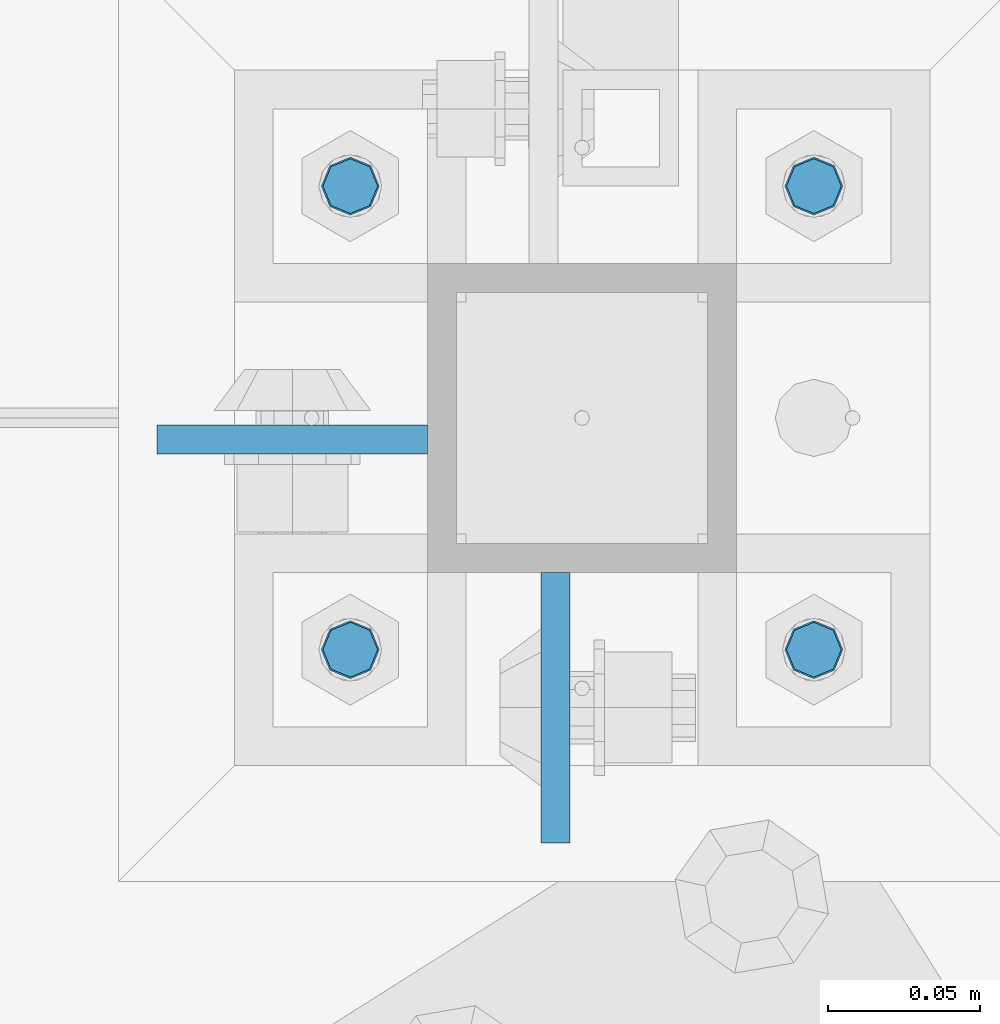
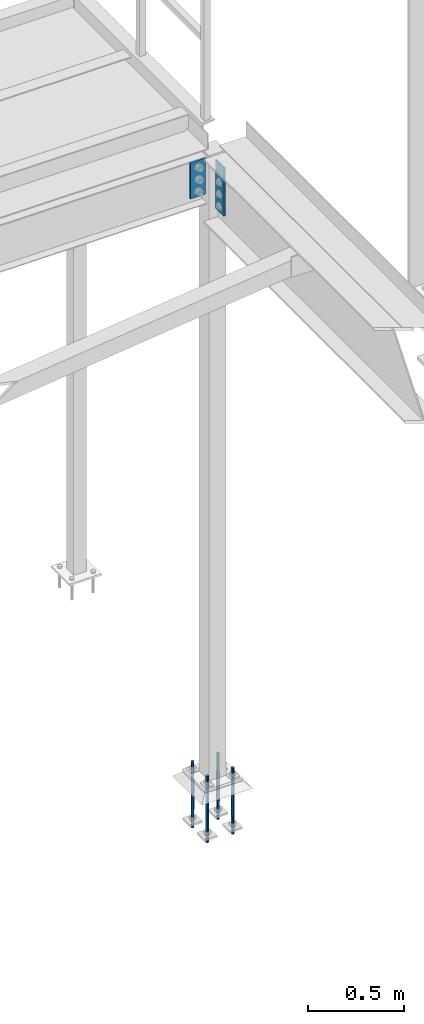
# One storey, part 1576 of 3843: 6 columns, 2 elements without a shape of their own.
"""IFC2X3 building model written with IfcOpenShell, lengths in millimetres."""

from ifc_helpers import new_model, si_unit, frame, origin_with_axes, place, context, subcontext, project, spatial, faceted_brep, material, type_object, element, aggregate, save


model = new_model("IFC2X3")

# Units and contexts
model_context = context("Model", 3, precision=1e-05, world=origin_with_axes())
body_context = subcontext(model_context, "Body", "Model", "MODEL_VIEW")
ifc_project = project(units=[si_unit("LENGTHUNIT", "METRE", prefix="MILLI"), si_unit("AREAUNIT", "SQUARE_METRE"), si_unit("VOLUMEUNIT", "CUBIC_METRE"), si_unit("MASSUNIT", "GRAM", prefix="KILO"), si_unit("TIMEUNIT", "SECOND"), si_unit("PLANEANGLEUNIT", "RADIAN"), si_unit("SOLIDANGLEUNIT", "STERADIAN"), si_unit("THERMODYNAMICTEMPERATUREUNIT", "DEGREE_CELSIUS"), si_unit("LUMINOUSINTENSITYUNIT", "LUMEN")], contexts=[model_context])

# Site, building, storey
site_placement = place(None, origin_with_axes())
site = spatial("IfcSite", under=ifc_project, at=site_placement, CompositionType="ELEMENT")
building_placement = place(site_placement, origin_with_axes())
building = spatial("IfcBuilding", under=site, at=building_placement, Name="Undefined", CompositionType="ELEMENT")
storey_placement = place(building_placement, origin_with_axes())
storey = spatial("IfcBuildingStorey", under=building, at=storey_placement, Name="Undefined", CompositionType="ELEMENT", Elevation=0.0)

# Assembly, columns
assembly_1_placement = place(storey_placement, origin_with_axes())
assembly_1 = element("IfcElementAssembly", 1, at=assembly_1_placement, inside=storey, Name="COLUMN", AssemblyPlace="NOTDEFINED", PredefinedType="RIGID_FRAME")
ifc_material_1 = material(Name="STEEL/A572-50")
column_type_1 = type_object("IfcColumnType", PredefinedType="NOTDEFINED")
column_1_placement = place(assembly_1_placement, frame((38811.9945000649, 89020.65, 33693.0999993376), z_axis=(0.0, 1.0, 0.0), x_axis=(0.0, 0.0, 1.0)))
column_1 = element("IfcColumn", 2, at=column_1_placement, type_object=column_type_1, material=ifc_material_1, Name="PLATE", context=body_context, shape_type="Brep", body=[
    faceted_brep([(0.0, 4.76249999999709, -44.4500000000007), (0.0, 4.76249999999709, 44.4500000000007), (304.799999999996, 4.76249999999709, 44.4500000000007), (304.799999999996, 4.76249999999709, -44.4500000000007), (0.0, -4.76249999999709, 44.4500000000007), (304.799999999996, -4.76249999999709, 44.4500000000007), (0.0, -4.76249999999709, -44.4500000000007), (304.799999999996, -4.76249999999709, -44.4500000000007)], [[[0, 1, 2, 3]], [[1, 4, 5, 2]], [[4, 6, 7, 5]], [[6, 0, 3, 7]], [[5, 7, 3, 2]], [[6, 4, 1, 0]]]),
])
column_2_placement = place(assembly_1_placement, frame((38725.475, 89108.756499958, 33769.3), z_axis=(1.0, 0.0, 0.0), x_axis=(0.0, 0.0, 1.0)))
column_2 = element("IfcColumn", 3, at=column_2_placement, type_object=column_type_1, material=ifc_material_1, Name="PLATE", context=body_context, shape_type="Brep", body=[
    faceted_brep([(0.0, 4.76249999999709, -44.4500000000007), (0.0, 4.76249999999709, 44.4500000000007), (228.599999999999, 4.76249999999709, 44.4500000000007), (228.599999999999, 4.76249999999709, -44.4500000000007), (0.0, -4.76249999999709, 44.4500000000007), (228.599999999999, -4.76249999999709, 44.4500000000007), (0.0, -4.76249999999709, -44.4500000000007), (228.599999999999, -4.76249999999709, -44.4500000000007)], [[[0, 1, 2, 3]], [[1, 4, 5, 2]], [[4, 6, 7, 5]], [[6, 0, 3, 7]], [[5, 7, 3, 2]], [[6, 4, 1, 0]]]),
])
aggregate(assembly_1, [column_1, column_2])

assembly_2_placement = place(storey_placement, origin_with_axes())
assembly_2 = element("IfcElementAssembly", 4, at=assembly_2_placement, inside=storey, Name="TEMPLATE", AssemblyPlace="NOTDEFINED", PredefinedType="RIGID_FRAME")
ifc_material_2 = material(Name="Undefined/F1554-GR.55")
column_type_2 = type_object("IfcColumnType", PredefinedType="NOTDEFINED")
column_3_placement = place(assembly_2_placement, frame((38896.925, 89039.7, 30022.8), z_axis=(1.0, 0.0, 0.0), x_axis=(0.0, 0.0, -1.0)))
column_3 = element("IfcColumn", 5, at=column_3_placement, type_object=column_type_2, material=ifc_material_2, Name="ANCHOR_ROD", context=body_context, shape_type="Brep", body=[
    faceted_brep([(-114.300000000003, -6.36396103068546, 6.36396103067818), (-114.300000000003, 0.0, 9.0), (-114.300000000003, 6.36396103068546, 6.36396103067818), (-114.300000000003, 9.0, 0.0), (-114.300000000003, 6.36396103068546, -6.36396103067818), (-114.300000000003, 0.0, -9.0), (-114.300000000003, -6.36396103068546, -6.36396103067818), (-114.300000000003, -9.0, 0.0), (0.0, 6.36396103068546, -6.36396103067818), (0.0, 0.0, -9.0), (0.0, -6.36396103068546, -6.36396103067818), (0.0, -9.0, 0.0), (0.0, -6.36396103068546, 6.36396103067818), (0.0, 0.0, 9.0), (0.0, 6.36396103068546, 6.36396103067818), (0.0, 9.0, 0.0), (0.0, -6.73519209080405, 6.73519209079677), (-9.87109982941227e-13, 2.91322521661641e-12, 9.52499961853027), (0.0, 6.73519209080405, 6.73519209079677), (0.0, 9.52500000000146, 0.0), (0.0, 6.73519209080405, -6.73519209079677), (2.95075507493764e-12, 2.91322521661641e-12, -9.52499961853027), (0.0, -6.73519209080405, -6.73519209079677), (0.0, -9.52500000000146, 0.0), (190.5, -9.52499999999418, 0.0), (190.5, -6.73519209079677, 6.73519209080405), (190.5, 0.0, 9.52500000000146), (190.5, 6.73519209079677, 6.73519209080405), (190.5, 9.52499999999418, 0.0), (190.5, 6.73519209079677, -6.73519209080405), (190.5, 0.0, -9.52500000000146), (190.5, -6.73519209079677, -6.73519209080405), (190.5, -6.36396103068546, 6.36396103067818), (190.5, 0.0, 9.0), (190.5, 6.36396103068546, 6.36396103067818), (190.5, 9.0, 0.0), (190.5, 6.36396103068546, -6.36396103067818), (190.5, 0.0, -9.0), (190.5, -6.36396103068546, -6.36396103067818), (190.5, -9.0, 0.0), (304.799999999999, 0.0, -9.0), (304.799999999999, 6.36396103068546, -6.36396103067818), (304.799999999999, 9.0, 0.0), (304.799999999999, 6.36396103068546, 6.36396103067818), (304.799999999999, 0.0, 9.0), (304.799999999999, -6.36396103068546, 6.36396103067818), (304.799999999999, -9.0, 0.0), (304.799999999999, -6.36396103068546, -6.36396103067818)], [[[0, 1, 2, 3, 4, 5, 6, 7]], [[5, 4, 8, 9]], [[6, 5, 9, 10]], [[7, 6, 10, 11]], [[0, 7, 11, 12]], [[1, 0, 12, 13]], [[2, 1, 13, 14]], [[3, 2, 14, 15]], [[4, 3, 15, 8]], [[16, 17, 18, 19, 20, 21, 22, 23], [14, 13, 12, 11, 10, 9, 8, 15]], [[16, 23, 24, 25]], [[17, 16, 25, 26]], [[18, 17, 26, 27]], [[19, 18, 27, 28]], [[20, 19, 28, 29]], [[21, 20, 29, 30]], [[22, 21, 30, 31]], [[23, 22, 31, 24]], [[30, 29, 28, 27, 26, 25, 24, 31], [32, 33, 34, 35, 36, 37, 38, 39]], [[40, 41, 42, 43, 44, 45, 46, 47]], [[45, 44, 33, 32]], [[46, 45, 32, 39]], [[47, 46, 39, 38]], [[40, 47, 38, 37]], [[41, 40, 37, 36]], [[42, 41, 36, 35]], [[43, 42, 35, 34]], [[44, 43, 34, 33]]]),
])
column_4_placement = place(assembly_2_placement, frame((38896.925, 89192.1, 30022.8), z_axis=(-1.0, 0.0, 0.0), x_axis=(0.0, 0.0, -1.0)))
column_4 = element("IfcColumn", 6, at=column_4_placement, type_object=column_type_2, material=ifc_material_2, Name="ANCHOR_ROD", context=body_context, shape_type="Brep", body=[
    faceted_brep([(-114.300000000003, -6.36396103068546, 6.36396103067818), (-114.300000000003, 0.0, 9.0), (-114.300000000003, 6.36396103068546, 6.36396103067818), (-114.300000000003, 9.0, 0.0), (-114.300000000003, 6.36396103068546, -6.36396103067818), (-114.300000000003, 0.0, -9.0), (-114.300000000003, -6.36396103068546, -6.36396103067818), (-114.300000000003, -9.0, 0.0), (0.0, 6.36396103068546, -6.36396103067818), (0.0, 0.0, -9.0), (0.0, -6.36396103068546, -6.36396103067818), (0.0, -9.0, 0.0), (0.0, -6.36396103068546, 6.36396103067818), (0.0, 0.0, 9.0), (0.0, 6.36396103068546, 6.36396103067818), (0.0, 9.0, 0.0), (0.0, -6.73519209080405, 6.73519209079677), (-9.87109982941227e-13, 2.91322521661641e-12, 9.52499961853027), (0.0, 6.73519209080405, 6.73519209079677), (0.0, 9.52500000000146, 0.0), (0.0, 6.73519209080405, -6.73519209079677), (2.95075507493764e-12, 2.91322521661641e-12, -9.52499961853027), (0.0, -6.73519209080405, -6.73519209079677), (0.0, -9.52500000000146, 0.0), (190.5, -9.52499999999418, 0.0), (190.5, -6.73519209079677, 6.73519209080405), (190.5, 0.0, 9.52500000000146), (190.5, 6.73519209079677, 6.73519209080405), (190.5, 9.52499999999418, 0.0), (190.5, 6.73519209079677, -6.73519209080405), (190.5, 0.0, -9.52500000000146), (190.5, -6.73519209079677, -6.73519209080405), (190.5, -6.36396103068546, 6.36396103067818), (190.5, 0.0, 9.0), (190.5, 6.36396103068546, 6.36396103067818), (190.5, 9.0, 0.0), (190.5, 6.36396103068546, -6.36396103067818), (190.5, 0.0, -9.0), (190.5, -6.36396103068546, -6.36396103067818), (190.5, -9.0, 0.0), (304.799999999999, 0.0, -9.0), (304.799999999999, 6.36396103068546, -6.36396103067818), (304.799999999999, 9.0, 0.0), (304.799999999999, 6.36396103068546, 6.36396103067818), (304.799999999999, 0.0, 9.0), (304.799999999999, -6.36396103068546, 6.36396103067818), (304.799999999999, -9.0, 0.0), (304.799999999999, -6.36396103068546, -6.36396103067818)], [[[0, 1, 2, 3, 4, 5, 6, 7]], [[5, 4, 8, 9]], [[6, 5, 9, 10]], [[7, 6, 10, 11]], [[0, 7, 11, 12]], [[1, 0, 12, 13]], [[2, 1, 13, 14]], [[3, 2, 14, 15]], [[4, 3, 15, 8]], [[16, 17, 18, 19, 20, 21, 22, 23], [14, 13, 12, 11, 10, 9, 8, 15]], [[16, 23, 24, 25]], [[17, 16, 25, 26]], [[18, 17, 26, 27]], [[19, 18, 27, 28]], [[20, 19, 28, 29]], [[21, 20, 29, 30]], [[22, 21, 30, 31]], [[23, 22, 31, 24]], [[30, 29, 28, 27, 26, 25, 24, 31], [32, 33, 34, 35, 36, 37, 38, 39]], [[40, 41, 42, 43, 44, 45, 46, 47]], [[45, 44, 33, 32]], [[46, 45, 32, 39]], [[47, 46, 39, 38]], [[40, 47, 38, 37]], [[41, 40, 37, 36]], [[42, 41, 36, 35]], [[43, 42, 35, 34]], [[44, 43, 34, 33]]]),
])
column_5_placement = place(assembly_2_placement, frame((38744.525, 89039.7, 30022.8), z_axis=(1.0, 0.0, 0.0), x_axis=(0.0, 0.0, -1.0)))
column_5 = element("IfcColumn", 7, at=column_5_placement, type_object=column_type_2, material=ifc_material_2, Name="ANCHOR_ROD", context=body_context, shape_type="Brep", body=[
    faceted_brep([(-114.300000000003, -6.36396103068546, 6.36396103067818), (-114.300000000003, 0.0, 9.0), (-114.300000000003, 6.36396103068546, 6.36396103067818), (-114.300000000003, 9.0, 0.0), (-114.300000000003, 6.36396103068546, -6.36396103067818), (-114.300000000003, 0.0, -9.0), (-114.300000000003, -6.36396103068546, -6.36396103067818), (-114.300000000003, -9.0, 0.0), (0.0, 6.36396103068546, -6.36396103067818), (0.0, 0.0, -9.0), (0.0, -6.36396103068546, -6.36396103067818), (0.0, -9.0, 0.0), (0.0, -6.36396103068546, 6.36396103067818), (0.0, 0.0, 9.0), (0.0, 6.36396103068546, 6.36396103067818), (0.0, 9.0, 0.0), (0.0, -6.73519209080405, 6.73519209079677), (-9.87109982941227e-13, 2.91322521661641e-12, 9.52499961853027), (0.0, 6.73519209080405, 6.73519209079677), (0.0, 9.52500000000146, 0.0), (0.0, 6.73519209080405, -6.73519209079677), (2.95075507493764e-12, 2.91322521661641e-12, -9.52499961853027), (0.0, -6.73519209080405, -6.73519209079677), (0.0, -9.52500000000146, 0.0), (190.5, -9.52499999999418, 0.0), (190.5, -6.73519209079677, 6.73519209080405), (190.5, 0.0, 9.52500000000146), (190.5, 6.73519209079677, 6.73519209080405), (190.5, 9.52499999999418, 0.0), (190.5, 6.73519209079677, -6.73519209080405), (190.5, 0.0, -9.52500000000146), (190.5, -6.73519209079677, -6.73519209080405), (190.5, -6.36396103068546, 6.36396103067818), (190.5, 0.0, 9.0), (190.5, 6.36396103068546, 6.36396103067818), (190.5, 9.0, 0.0), (190.5, 6.36396103068546, -6.36396103067818), (190.5, 0.0, -9.0), (190.5, -6.36396103068546, -6.36396103067818), (190.5, -9.0, 0.0), (304.799999999999, 0.0, -9.0), (304.799999999999, 6.36396103068546, -6.36396103067818), (304.799999999999, 9.0, 0.0), (304.799999999999, 6.36396103068546, 6.36396103067818), (304.799999999999, 0.0, 9.0), (304.799999999999, -6.36396103068546, 6.36396103067818), (304.799999999999, -9.0, 0.0), (304.799999999999, -6.36396103068546, -6.36396103067818)], [[[0, 1, 2, 3, 4, 5, 6, 7]], [[5, 4, 8, 9]], [[6, 5, 9, 10]], [[7, 6, 10, 11]], [[0, 7, 11, 12]], [[1, 0, 12, 13]], [[2, 1, 13, 14]], [[3, 2, 14, 15]], [[4, 3, 15, 8]], [[16, 17, 18, 19, 20, 21, 22, 23], [14, 13, 12, 11, 10, 9, 8, 15]], [[16, 23, 24, 25]], [[17, 16, 25, 26]], [[18, 17, 26, 27]], [[19, 18, 27, 28]], [[20, 19, 28, 29]], [[21, 20, 29, 30]], [[22, 21, 30, 31]], [[23, 22, 31, 24]], [[30, 29, 28, 27, 26, 25, 24, 31], [32, 33, 34, 35, 36, 37, 38, 39]], [[40, 41, 42, 43, 44, 45, 46, 47]], [[45, 44, 33, 32]], [[46, 45, 32, 39]], [[47, 46, 39, 38]], [[40, 47, 38, 37]], [[41, 40, 37, 36]], [[42, 41, 36, 35]], [[43, 42, 35, 34]], [[44, 43, 34, 33]]]),
])
column_6_placement = place(assembly_2_placement, frame((38744.525, 89192.1, 30022.8), z_axis=(-1.0, 0.0, 0.0), x_axis=(0.0, 0.0, -1.0)))
column_6 = element("IfcColumn", 8, at=column_6_placement, type_object=column_type_2, material=ifc_material_2, Name="ANCHOR_ROD", context=body_context, shape_type="Brep", body=[
    faceted_brep([(-114.300000000003, -6.36396103068546, 6.36396103067818), (-114.300000000003, 0.0, 9.0), (-114.300000000003, 6.36396103068546, 6.36396103067818), (-114.300000000003, 9.0, 0.0), (-114.300000000003, 6.36396103068546, -6.36396103067818), (-114.300000000003, 0.0, -9.0), (-114.300000000003, -6.36396103068546, -6.36396103067818), (-114.300000000003, -9.0, 0.0), (0.0, 6.36396103068546, -6.36396103067818), (0.0, 0.0, -9.0), (0.0, -6.36396103068546, -6.36396103067818), (0.0, -9.0, 0.0), (0.0, -6.36396103068546, 6.36396103067818), (0.0, 0.0, 9.0), (0.0, 6.36396103068546, 6.36396103067818), (0.0, 9.0, 0.0), (0.0, -6.73519209080405, 6.73519209079677), (-9.87109982941227e-13, 2.91322521661641e-12, 9.52499961853027), (0.0, 6.73519209080405, 6.73519209079677), (0.0, 9.52500000000146, 0.0), (0.0, 6.73519209080405, -6.73519209079677), (2.95075507493764e-12, 2.91322521661641e-12, -9.52499961853027), (0.0, -6.73519209080405, -6.73519209079677), (0.0, -9.52500000000146, 0.0), (190.5, -9.52499999999418, 0.0), (190.5, -6.73519209079677, 6.73519209080405), (190.5, 0.0, 9.52500000000146), (190.5, 6.73519209079677, 6.73519209080405), (190.5, 9.52499999999418, 0.0), (190.5, 6.73519209079677, -6.73519209080405), (190.5, 0.0, -9.52500000000146), (190.5, -6.73519209079677, -6.73519209080405), (190.5, -6.36396103068546, 6.36396103067818), (190.5, 0.0, 9.0), (190.5, 6.36396103068546, 6.36396103067818), (190.5, 9.0, 0.0), (190.5, 6.36396103068546, -6.36396103067818), (190.5, 0.0, -9.0), (190.5, -6.36396103068546, -6.36396103067818), (190.5, -9.0, 0.0), (304.799999999999, 0.0, -9.0), (304.799999999999, 6.36396103068546, -6.36396103067818), (304.799999999999, 9.0, 0.0), (304.799999999999, 6.36396103068546, 6.36396103067818), (304.799999999999, 0.0, 9.0), (304.799999999999, -6.36396103068546, 6.36396103067818), (304.799999999999, -9.0, 0.0), (304.799999999999, -6.36396103068546, -6.36396103067818)], [[[0, 1, 2, 3, 4, 5, 6, 7]], [[5, 4, 8, 9]], [[6, 5, 9, 10]], [[7, 6, 10, 11]], [[0, 7, 11, 12]], [[1, 0, 12, 13]], [[2, 1, 13, 14]], [[3, 2, 14, 15]], [[4, 3, 15, 8]], [[16, 17, 18, 19, 20, 21, 22, 23], [14, 13, 12, 11, 10, 9, 8, 15]], [[16, 23, 24, 25]], [[17, 16, 25, 26]], [[18, 17, 26, 27]], [[19, 18, 27, 28]], [[20, 19, 28, 29]], [[21, 20, 29, 30]], [[22, 21, 30, 31]], [[23, 22, 31, 24]], [[30, 29, 28, 27, 26, 25, 24, 31], [32, 33, 34, 35, 36, 37, 38, 39]], [[40, 41, 42, 43, 44, 45, 46, 47]], [[45, 44, 33, 32]], [[46, 45, 32, 39]], [[47, 46, 39, 38]], [[40, 47, 38, 37]], [[41, 40, 37, 36]], [[42, 41, 36, 35]], [[43, 42, 35, 34]], [[44, 43, 34, 33]]]),
])
aggregate(assembly_2, [column_3, column_4, column_5, column_6])

save(model, "model.ifc")
